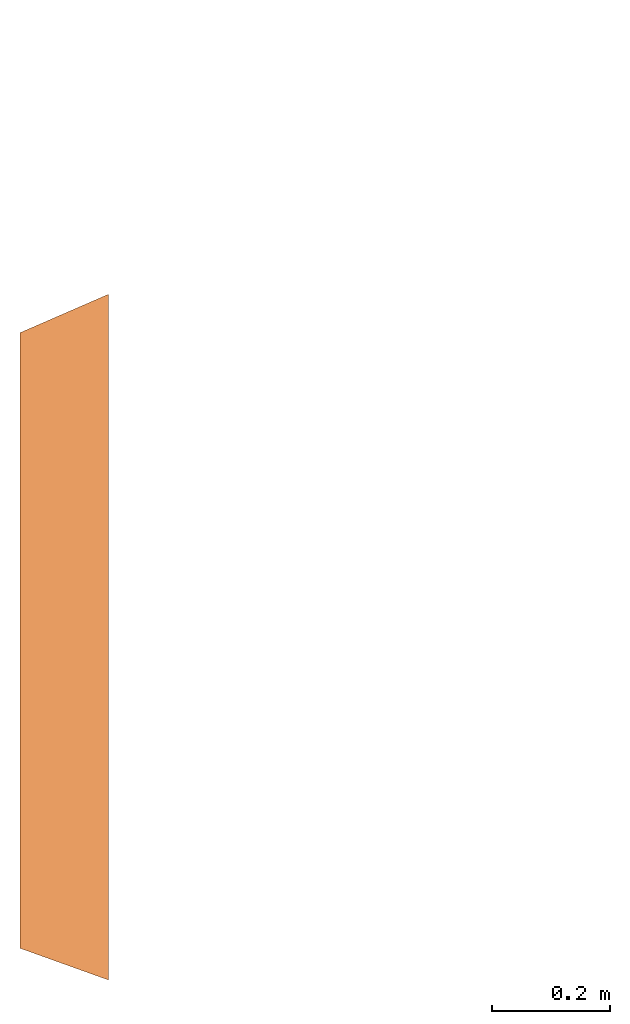
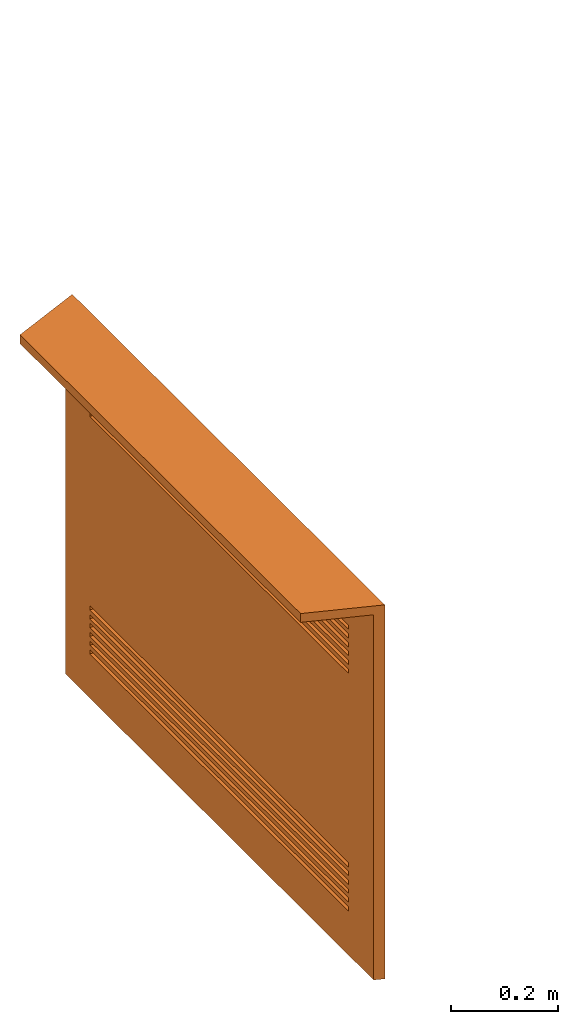
# One storey, part 2 of 2: 1 proxy, 12 openings.
"""IFC4 building model written with IfcOpenShell, lengths in metres."""

from ifc_helpers import new_model, entity, si_unit, converted_unit, derived_unit, direction, frame, origin, place, context, subcontext, project, spatial, indexed_curve, outline, extrude, source, transform, mapped, material, type_object, type_shapes, element, save


model = new_model("IFC4")

# Units and contexts
model_context = context("Model", 3, precision=1e-05, world=origin(), true_north=direction((6.123233995736766e-17, 1.0)))
body_context = subcontext(model_context, "Body", "Model", "MODEL_VIEW")
ifc_project = project(units=[si_unit("LENGTHUNIT", "METRE"), si_unit("AREAUNIT", "SQUARE_METRE"), si_unit("VOLUMEUNIT", "CUBIC_METRE"), converted_unit("PLANEANGLEUNIT", "DEGREE", entity("IfcPlaneAngleMeasure", 0.017453292519943278), si_unit("PLANEANGLEUNIT", "RADIAN"), dimensions=[0, 0, 0, 0, 0, 0, 0]), derived_unit("THERMALTRANSMITTANCEUNIT", [(si_unit("MASSUNIT", "GRAM", prefix="KILO"), 1), (si_unit("THERMODYNAMICTEMPERATUREUNIT", "KELVIN"), -1), (si_unit("TIMEUNIT", "SECOND"), -3)])], contexts=[model_context])

# Site, building, storey
site_placement = place(None, origin())
site = spatial("IfcSite", under=ifc_project, at=site_placement, CompositionType="ELEMENT")
building_placement = place(site_placement, origin())
building = spatial("IfcBuilding", under=site, at=building_placement, CompositionType="ELEMENT")
storey_placement = place(building_placement, frame((0.0, 0.0, -0.12999999999999998)))
storey = spatial("IfcBuildingStorey", under=building, at=storey_placement, Name="- 0.13 m", CompositionType="ELEMENT", Elevation=-0.12999999999999998)

# Proxy, openings
ifc_material = material()
building_element_proxy_type = type_object("IfcBuildingElementProxyType", Name="Famiglia2:Famiglia2", PredefinedType="NOTDEFINED", material=ifc_material)
shared_shape = source(origin(), body_context, "Body", "SweptSolid", [
    extrude(outline(indexed_curve([(-0.5791348421766498, -0.07500000000000248), (0.5848503503881871, -0.07500000000000248), (0.5195760053616856, 0.07500000000000248), (-0.5252915135732229, 0.07500000000000248), (-0.5791348421766498, -0.07500000000000248)], self_intersect=False)), frame((-0.002857754105759479, -0.07499999999999404, -0.020000000000001853), z_axis=(0.0, 0.0, 1.0), x_axis=(-1.0, 0.0, 0.0)), (0.0, 0.0, 1.0), 0.019999999999968827),
    extrude(outline(indexed_curve([(-0.5816115624016492, -0.009999999999999998), (0.5823736301631874, -0.009999999999999998), (0.5736703841596543, 0.00999999999999999), (-0.5744324519211925, 0.010000000000000002), (-0.5816115624016492, -0.009999999999999998)], self_intersect=False)), frame((-0.005334474330758925, -0.009999999999991573, -0.8500000000000019), z_axis=(0.0, 0.0, 1.0), x_axis=(-1.0, 0.0, 0.0)), (0.0, 0.0, 1.0), 0.8499999999999686),
])
type_shapes(building_element_proxy_type, [shared_shape])
proxy_placement = place(storey_placement, frame((-4.633266834912519, 3.4968976107241576, 0.8795424772110505), z_axis=(0.0, 0.0, 1.0), x_axis=(-1.111997565699547e-07, -1.0, 0.0)))
proxy = element("IfcBuildingElementProxy", 1, at=proxy_placement, inside=storey, type_object=building_element_proxy_type, material=ifc_material, Name="Famiglia2:Famiglia2", ObjectType="Famiglia2:Famiglia2", PredefinedType="NOTDEFINED", context=body_context, shape_type="MappedRepresentation", body=[
    mapped(shared_shape, transform((0.0, 0.0, 0.0), scale=1.0)),
])
opening_1_placement = place(storey_placement, frame((-4.633266834912519, 3.4968976107241576, 0.7495424772110505), z_axis=(0.0, 0.0, 1.0), x_axis=(-1.0, 2.2239951313990804e-07, 0.0)))
element("IfcOpeningElement", 2, at=opening_1_placement, cuts=proxy, Name="Famiglia2:Famiglia2:1", PredefinedType="OPENING", context=body_context, shape_type="SweptSolid", body=[
    extrude(outline(indexed_curve([(-0.005000000000000014, -0.48199259628241814), (0.00499999999999998, -0.48199259628241814), (0.00499999999999998, 0.48199259628241814), (-0.005000000000000014, 0.48199259628241814), (-0.005000000000000014, -0.48199259628241814)], self_intersect=False)), frame((0.0, -0.005715508211537941, -0.07499999999995821), z_axis=(1.0, 1.111997565699547e-07, 0.0), x_axis=(0.0, 0.0, -1.0)), (0.0, 0.0, 1.0), 0.02),
])
opening_2_placement = place(storey_placement, frame((-4.633266834912519, 3.4968976107241576, 0.7495424772110505), z_axis=(0.0, 0.0, 1.0), x_axis=(-1.0, 2.2239951313990804e-07, 0.0)))
element("IfcOpeningElement", 3, at=opening_2_placement, cuts=proxy, Name="Famiglia2:Famiglia2:2", PredefinedType="OPENING", context=body_context, shape_type="SweptSolid", body=[
    extrude(outline(indexed_curve([(-0.005000000000000014, -0.48199259628241814), (0.00499999999999998, -0.48199259628241814), (0.00499999999999998, 0.48199259628241814), (-0.005000000000000014, 0.48199259628241814), (-0.005000000000000014, -0.48199259628241814)], self_intersect=False)), frame((0.0, -0.005715508211537941, -0.05499999999995823), z_axis=(1.0, 1.111997565699547e-07, 0.0), x_axis=(0.0, 0.0, -1.0)), (0.0, 0.0, 1.0), 0.02),
])
opening_3_placement = place(storey_placement, frame((-4.633266834912519, 3.4968976107241576, 0.7495424772110505), z_axis=(0.0, 0.0, 1.0), x_axis=(-1.0, 2.2239951313990804e-07, 0.0)))
element("IfcOpeningElement", 4, at=opening_3_placement, cuts=proxy, Name="Famiglia2:Famiglia2:3", PredefinedType="OPENING", context=body_context, shape_type="SweptSolid", body=[
    extrude(outline(indexed_curve([(-0.005000000000000014, -0.48199259628241814), (0.00499999999999998, -0.48199259628241814), (0.00499999999999998, 0.48199259628241814), (-0.005000000000000014, 0.48199259628241814), (-0.005000000000000014, -0.48199259628241814)], self_intersect=False)), frame((0.0, -0.005715508211537941, -0.03499999999995824), z_axis=(1.0, 1.111997565699547e-07, 0.0), x_axis=(0.0, 0.0, -1.0)), (0.0, 0.0, 1.0), 0.02),
])
opening_4_placement = place(storey_placement, frame((-4.633266834912519, 3.4968976107241576, 0.7495424772110505), z_axis=(0.0, 0.0, 1.0), x_axis=(-1.0, 2.2239951313990804e-07, 0.0)))
element("IfcOpeningElement", 5, at=opening_4_placement, cuts=proxy, Name="Famiglia2:Famiglia2:4", PredefinedType="OPENING", context=body_context, shape_type="SweptSolid", body=[
    extrude(outline(indexed_curve([(-0.004999999999999997, -0.48199259628241814), (0.004999999999999997, -0.48199259628241814), (0.004999999999999997, 0.48199259628241814), (-0.004999999999999997, 0.48199259628241814), (-0.004999999999999997, -0.48199259628241814)], self_intersect=False)), frame((0.0, -0.005715508211537941, -0.014999999999958233), z_axis=(1.0, 1.111997565699547e-07, 0.0), x_axis=(0.0, 0.0, -1.0)), (0.0, 0.0, 1.0), 0.02),
])
opening_5_placement = place(storey_placement, frame((-4.633266834912519, 3.4968976107241576, 0.7495424772110505), z_axis=(0.0, 0.0, 1.0), x_axis=(-1.0, 2.2239951313990804e-07, 0.0)))
element("IfcOpeningElement", 6, at=opening_5_placement, cuts=proxy, Name="Famiglia2:Famiglia2:5", PredefinedType="OPENING", context=body_context, shape_type="SweptSolid", body=[
    extrude(outline(indexed_curve([(-0.004999999999999997, -0.48199259628241814), (0.004999999999999997, -0.48199259628241814), (0.004999999999999997, 0.48199259628241814), (-0.004999999999999997, 0.48199259628241814), (-0.004999999999999997, -0.48199259628241814)], self_intersect=False)), frame((0.0, -0.005715508211537941, 0.005000000000041755), z_axis=(1.0, 1.111997565699547e-07, 0.0), x_axis=(0.0, 0.0, -1.0)), (0.0, 0.0, 1.0), 0.02),
])
opening_6_placement = place(storey_placement, frame((-4.633266834912519, 3.4968976107241576, 0.7495424772110505), z_axis=(0.0, 0.0, 1.0), x_axis=(-1.0, 2.2239951313990804e-07, 0.0)))
element("IfcOpeningElement", 7, at=opening_6_placement, cuts=proxy, Name="Famiglia2:Famiglia2:6", PredefinedType="OPENING", context=body_context, shape_type="SweptSolid", body=[
    extrude(outline(indexed_curve([(-0.004999999999999997, -0.48199259628241814), (0.004999999999999997, -0.48199259628241814), (0.004999999999999997, 0.48199259628241814), (-0.004999999999999997, 0.48199259628241814), (-0.004999999999999997, -0.48199259628241814)], self_intersect=False)), frame((0.0, -0.005715508211537941, 0.025000000000041742), z_axis=(1.0, 1.111997565699547e-07, 0.0), x_axis=(0.0, 0.0, -1.0)), (0.0, 0.0, 1.0), 0.02),
])
opening_7_placement = place(storey_placement, frame((-4.633266834912519, 3.4968976107241576, 0.7495424772110505), z_axis=(0.0, 0.0, 1.0), x_axis=(-1.0, 2.2239951313990804e-07, 0.0)))
element("IfcOpeningElement", 8, at=opening_7_placement, cuts=proxy, Name="Famiglia2:Famiglia2:7", PredefinedType="OPENING", context=body_context, shape_type="SweptSolid", body=[
    extrude(outline(indexed_curve([(-0.004999999999970032, -0.48199259628241814), (0.004999999999970167, -0.48199259628241814), (0.004999999999970167, 0.48199259628241814), (-0.004999999999970032, 0.48199259628241814), (-0.004999999999970032, -0.48199259628241814)], self_intersect=False)), frame((0.0, -0.005715508211537941, -0.6149999999999284), z_axis=(1.0, 1.111997565699547e-07, 0.0), x_axis=(0.0, 0.0, -1.0)), (0.0, 0.0, 1.0), 0.02),
])
opening_8_placement = place(storey_placement, frame((-4.633266834912519, 3.4968976107241576, 0.7495424772110505), z_axis=(0.0, 0.0, 1.0), x_axis=(-1.0, 2.2239951313990804e-07, 0.0)))
element("IfcOpeningElement", 9, at=opening_8_placement, cuts=proxy, Name="Famiglia2:Famiglia2:8", PredefinedType="OPENING", context=body_context, shape_type="SweptSolid", body=[
    extrude(outline(indexed_curve([(-0.004999999999999946, -0.48199259628241814), (0.004999999999999946, -0.48199259628241814), (0.004999999999999946, 0.48199259628241814), (-0.004999999999999946, 0.48199259628241814), (-0.004999999999999946, -0.48199259628241814)], self_intersect=False)), frame((0.0, -0.005715508211537941, -0.5949999999999586), z_axis=(1.0, 1.111997565699547e-07, 0.0), x_axis=(0.0, 0.0, -1.0)), (0.0, 0.0, 1.0), 0.02),
])
opening_9_placement = place(storey_placement, frame((-4.633266834912519, 3.4968976107241576, 0.7495424772110505), z_axis=(0.0, 0.0, 1.0), x_axis=(-1.0, 2.2239951313990804e-07, 0.0)))
element("IfcOpeningElement", 10, at=opening_9_placement, cuts=proxy, Name="Famiglia2:Famiglia2:9", PredefinedType="OPENING", context=body_context, shape_type="SweptSolid", body=[
    extrude(outline(indexed_curve([(-0.004999999999999946, -0.48199259628241814), (0.004999999999999946, -0.48199259628241814), (0.004999999999999946, 0.48199259628241814), (-0.004999999999999946, 0.48199259628241814), (-0.004999999999999946, -0.48199259628241814)], self_intersect=False)), frame((0.0, -0.005715508211537941, -0.5749999999999588), z_axis=(1.0, 1.111997565699547e-07, 0.0), x_axis=(0.0, 0.0, -1.0)), (0.0, 0.0, 1.0), 0.02),
])
opening_10_placement = place(storey_placement, frame((-4.633266834912519, 3.4968976107241576, 0.7495424772110505), z_axis=(0.0, 0.0, 1.0), x_axis=(-1.0, 2.2239951313990804e-07, 0.0)))
element("IfcOpeningElement", 11, at=opening_10_placement, cuts=proxy, Name="Famiglia2:Famiglia2:10", PredefinedType="OPENING", context=body_context, shape_type="SweptSolid", body=[
    extrude(outline(indexed_curve([(-0.004999999999999946, -0.48199259628241814), (0.004999999999999946, -0.48199259628241814), (0.004999999999999946, 0.48199259628241814), (-0.004999999999999946, 0.48199259628241814), (-0.004999999999999946, -0.48199259628241814)], self_intersect=False)), frame((0.0, -0.005715508211537941, -0.554999999999959), z_axis=(1.0, 1.111997565699547e-07, 0.0), x_axis=(0.0, 0.0, -1.0)), (0.0, 0.0, 1.0), 0.02),
])
opening_11_placement = place(storey_placement, frame((-4.633266834912519, 3.4968976107241576, 0.7495424772110505), z_axis=(0.0, 0.0, 1.0), x_axis=(-1.0, 2.2239951313990804e-07, 0.0)))
element("IfcOpeningElement", 12, at=opening_11_placement, cuts=proxy, Name="Famiglia2:Famiglia2:11", PredefinedType="OPENING", context=body_context, shape_type="SweptSolid", body=[
    extrude(outline(indexed_curve([(-0.004999999999999946, -0.48199259628241814), (0.004999999999999946, -0.48199259628241814), (0.004999999999999946, 0.48199259628241814), (-0.004999999999999946, 0.48199259628241814), (-0.004999999999999946, -0.48199259628241814)], self_intersect=False)), frame((0.0, -0.005715508211537941, -0.5349999999999592), z_axis=(1.0, 1.111997565699547e-07, 0.0), x_axis=(0.0, 0.0, -1.0)), (0.0, 0.0, 1.0), 0.02),
])
opening_12_placement = place(storey_placement, frame((-4.633266834912519, 3.4968976107241576, 0.7495424772110505), z_axis=(0.0, 0.0, 1.0), x_axis=(-1.0, 2.2239951313990804e-07, 0.0)))
element("IfcOpeningElement", 13, at=opening_12_placement, cuts=proxy, Name="Famiglia2:Famiglia2:12", PredefinedType="OPENING", context=body_context, shape_type="SweptSolid", body=[
    extrude(outline(indexed_curve([(-0.004999999999999946, -0.48199259628241814), (0.004999999999999946, -0.48199259628241814), (0.004999999999999946, 0.48199259628241814), (-0.004999999999999946, 0.48199259628241814), (-0.004999999999999946, -0.48199259628241814)], self_intersect=False)), frame((0.0, -0.005715508211537941, -0.5149999999999594), z_axis=(1.0, 1.111997565699547e-07, 0.0), x_axis=(0.0, 0.0, -1.0)), (0.0, 0.0, 1.0), 0.02),
])

save(model, "model.ifc")
